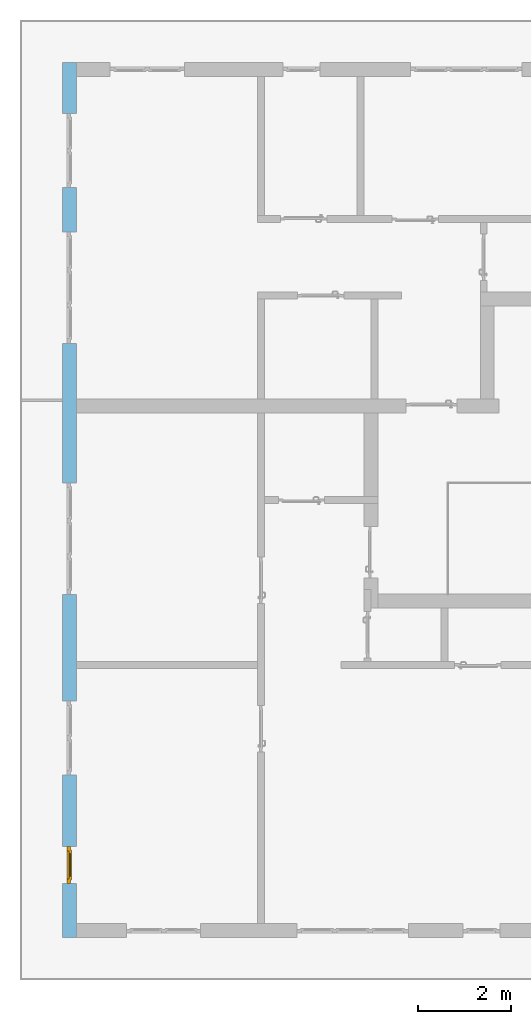
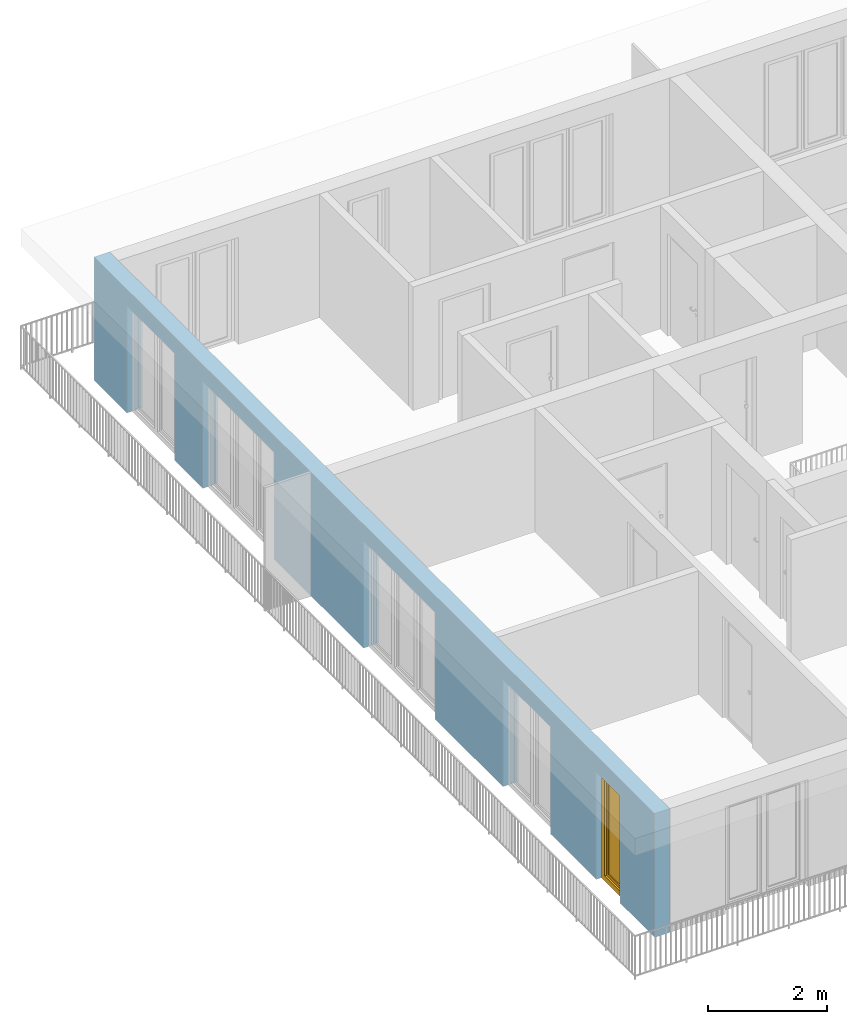
# One storey, part 12 of 54: 1 window, 5 openings, plus 1 element that does not belong to this part.
"""IFC4 building model written with IfcOpenShell, lengths in metres."""

from ifc_helpers import new_model, entity, si_unit, converted_unit, derived_unit, direction, frame, origin_with_axes, place, context, subcontext, project, spatial, polygons, source, transform, mapped, material, type_object, element, fill, save


model = new_model("IFC4")

# Units and contexts
model_context = context("Model", 3, precision=1e-05, world=origin_with_axes(), true_north=direction((0.0, 1.0)))
body_context = subcontext(model_context, "Body", "Model", "MODEL_VIEW")
ifc_project = project(units=[si_unit("LENGTHUNIT", "METRE"), si_unit("AREAUNIT", "SQUARE_METRE"), si_unit("VOLUMEUNIT", "CUBIC_METRE"), converted_unit("PLANEANGLEUNIT", "DEGREE", entity("IfcPlaneAngleMeasure", 0.0174532925199), si_unit("PLANEANGLEUNIT", "RADIAN"), dimensions=[0, 0, 0, 0, 0, 0, 0]), converted_unit("TIMEUNIT", "Year", entity("IfcTimeMeasure", 31556926.0), si_unit("TIMEUNIT", "SECOND"), dimensions=[0, 0, 1, 0, 0, 0, 0]), si_unit("MASSUNIT", "GRAM", prefix="KILO"), si_unit("THERMODYNAMICTEMPERATUREUNIT", "DEGREE_CELSIUS"), si_unit("LUMINOUSINTENSITYUNIT", "LUMEN"), si_unit("ENERGYUNIT", "JOULE", prefix="MEGA"), derived_unit("THERMALCONDUCTANCEUNIT", [(si_unit("POWERUNIT", "WATT"), 1), (si_unit("LENGTHUNIT", "METRE"), -1), (si_unit("THERMODYNAMICTEMPERATUREUNIT", "KELVIN"), -1)]), derived_unit("SPECIFICHEATCAPACITYUNIT", [(si_unit("ENERGYUNIT", "JOULE"), 1), (si_unit("MASSUNIT", "GRAM", prefix="KILO"), -1), (si_unit("THERMODYNAMICTEMPERATUREUNIT", "KELVIN"), -1)]), derived_unit("MASSDENSITYUNIT", [(si_unit("MASSUNIT", "GRAM", prefix="KILO"), 1), (si_unit("VOLUMEUNIT", "CUBIC_METRE"), -1)])], contexts=[model_context])

# Site, building, storey
site_placement = place(None, origin_with_axes())
site = spatial("IfcSite", under=ifc_project, at=site_placement, CompositionType="ELEMENT")
building_placement = place(site_placement, origin_with_axes())
building = spatial("IfcBuilding", under=site, at=building_placement, CompositionType="ELEMENT")
storey_placement = place(building_placement, frame((0.0, 0.0, 9.18), z_axis=(0.0, 0.0, 1.0), x_axis=(1.0, 0.0, 0.0)))
storey = spatial("IfcBuildingStorey", under=building, at=storey_placement, Name="3. Geschoss", CompositionType="ELEMENT", Elevation=9.18)

# Wall, openings, window
ifc_material = material()
wall_type = type_object("IfcWallType", Name="300", PredefinedType="NOTDEFINED")
wall_placement = place(storey_placement, frame((-11.7421993804, -9.92881223104, 0.0), z_axis=(0.0, 0.0, 1.0), x_axis=(0.0, 1.0, 0.0)))
wall = element("IfcWall", 1, at=wall_placement, inside=storey, type_object=wall_type, material=ifc_material, Name="Wand-001", PredefinedType="NOTDEFINED", context=body_context, shape_type="Tessellation", body=[
    polygons([(1.16441876325, -0.3, 0.0), (1.16441876325, -0.3, 2.2), (1.96441876325, -0.3, 2.2), (1.96441876325, -0.3, 0.0), (3.5, -0.3, 0.0), (3.5, -0.3, 2.2), (5.1, -0.3, 2.2), (5.1, -0.3, 0.0), (7.3921181063, -0.3, 0.0), (7.3921181063, -0.3, 2.2), (9.7921181063, -0.3, 2.2), (9.7921181063, -0.3, 0.0), (12.8, -0.3, 0.0), (12.8, -0.3, 2.2), (15.2, -0.3, 2.2), (15.2, -0.3, 0.0), (16.15, -0.3, 0.0), (16.15, -0.3, 2.2), (17.75, -0.3, 2.2), (17.75, -0.3, 0.0), (18.85, -0.3, 0.0), (18.85, -0.3, 2.54), (0.0, -0.3, 2.54), (0.0, -0.3, 0.0), (1.16441876325, -0.1, 0.0), (1.16441876325, -0.1, 2.2), (1.96441876325, -0.1, 2.2), (1.96441876325, -0.1, 0.0), (1.96441876325, 0.0, 0.0), (3.5, 0.0, 0.0), (3.5, -0.1, 0.0), (3.5, -0.1, 2.2), (5.1, -0.1, 2.2), (5.1, -0.1, 0.0), (5.1, 0.0, 0.0), (7.3921181063, 0.0, 0.0), (7.3921181063, -0.1, 0.0), (7.3921181063, -0.1, 2.2), (9.7921181063, -0.1, 2.2), (9.7921181063, -0.1, 0.0), (9.7921181063, 0.0, 0.0), (12.8, 0.0, 0.0), (12.8, -0.1, 0.0), (12.8, -0.1, 2.2), (15.2, -0.1, 2.2), (15.2, -0.1, 0.0), (15.2, 0.0, 0.0), (16.15, 0.0, 0.0), (16.15, -0.1, 0.0), (16.15, -0.1, 2.2), (17.75, -0.1, 2.2), (17.75, -0.1, 0.0), (17.75, 0.0, 0.0), (18.85, 0.0, 0.0), (18.85, 0.0, 2.54), (0.0, 0.0, 2.54), (0.0, 0.0, 0.0), (1.16441876325, 0.0, 0.0), (1.16441876325, 0.0, 2.2), (1.96441876325, 0.0, 2.2), (17.75, 0.0, 2.2), (16.15, 0.0, 2.2), (15.2, 0.0, 2.2), (12.8, 0.0, 2.2), (9.7921181063, 0.0, 2.2), (7.3921181063, 0.0, 2.2), (5.1, 0.0, 2.2), (3.5, 0.0, 2.2)], [[[1, 2, 3, 4, 5, 6, 7, 8, 9, 10, 11, 12, 13, 14, 15, 16, 17, 18, 19, 20, 21, 22, 23, 24]], [[2, 1, 25, 26]], [[3, 2, 26, 27]], [[4, 3, 27, 28]], [[4, 28, 29, 30, 31, 5]], [[31, 32, 6, 5]], [[32, 33, 7, 6]], [[33, 34, 8, 7]], [[8, 34, 35, 36, 37, 9]], [[10, 9, 37, 38]], [[11, 10, 38, 39]], [[12, 11, 39, 40]], [[12, 40, 41, 42, 43, 13]], [[43, 44, 14, 13]], [[44, 45, 15, 14]], [[45, 46, 16, 15]], [[16, 46, 47, 48, 49, 17]], [[18, 17, 49, 50]], [[19, 18, 50, 51]], [[20, 19, 51, 52]], [[52, 53, 54, 21, 20]], [[22, 21, 54, 55]], [[22, 55, 56, 23]], [[56, 57, 24, 23]], [[25, 1, 24, 57, 58]], [[26, 25, 58, 59]], [[27, 26, 59, 60]], [[28, 27, 60, 29]], [[30, 29, 60, 59, 58, 57, 56, 55, 54, 53, 61, 62, 48, 47, 63, 64, 42, 41, 65, 66, 36, 35, 67, 68]], [[30, 68, 32, 31]], [[68, 67, 33, 32]], [[67, 35, 34, 33]], [[38, 37, 36, 66]], [[39, 38, 66, 65]], [[40, 39, 65, 41]], [[42, 64, 44, 43]], [[64, 63, 45, 44]], [[63, 47, 46, 45]], [[50, 49, 48, 62]], [[51, 50, 62, 61]], [[52, 51, 61, 53]]], closed=True),
])
opening_1_placement = place(wall_placement, frame((16.95, 0.0, 0.0), z_axis=(0.0, 0.0, 1.0), x_axis=(1.0, 0.0, 0.0)))
element("IfcOpeningElement", 2, at=opening_1_placement, cuts=wall, Name="Fenster-001", context=body_context, identifier="Reference", shape_type="Tessellation", body=[
    polygons([(-0.8, -0.1, 0.0), (-0.8, -0.1, 2.2), (-0.8, 0.000999999999999, 2.2), (-0.8, 0.000999999999999, 0.0), (-0.8, -0.301, 0.0), (-0.8, -0.301, 2.2), (0.8, -0.1, 2.2), (0.8, 0.000999999999999, 2.2), (0.8, -0.301, 2.2), (0.8, 0.000999999999999, 0.0), (0.8, -0.1, 0.0), (0.8, -0.301, 0.0)], [[[1, 2, 3, 4]], [[2, 1, 5, 6]], [[7, 8, 3, 2, 6, 9]], [[8, 10, 4, 3]], [[1, 4, 10, 11, 12, 5]], [[6, 5, 12, 9]], [[7, 11, 10, 8]], [[11, 7, 9, 12]]], closed=True),
])
opening_2_placement = place(wall_placement, frame((14.0, 0.0, 0.0), z_axis=(0.0, 0.0, 1.0), x_axis=(1.0, 0.0, 0.0)))
element("IfcOpeningElement", 3, at=opening_2_placement, cuts=wall, Name="Fenster-002", context=body_context, identifier="Reference", shape_type="Tessellation", body=[
    polygons([(-1.2, -0.1, 0.0), (-1.2, -0.1, 2.2), (-1.2, 0.000999999999999, 2.2), (-1.2, 0.000999999999999, 0.0), (-1.2, -0.301, 0.0), (-1.2, -0.301, 2.2), (1.2, -0.1, 2.2), (1.2, 0.000999999999999, 2.2), (1.2, -0.301, 2.2), (1.2, 0.000999999999999, 0.0), (1.2, -0.1, 0.0), (1.2, -0.301, 0.0)], [[[1, 2, 3, 4]], [[2, 1, 5, 6]], [[7, 8, 3, 2, 6, 9]], [[8, 10, 4, 3]], [[1, 4, 10, 11, 12, 5]], [[6, 5, 12, 9]], [[7, 11, 10, 8]], [[11, 7, 9, 12]]], closed=True),
])
opening_3_placement = place(wall_placement, frame((8.5921181063, 0.0, 0.0), z_axis=(0.0, 0.0, 1.0), x_axis=(1.0, 0.0, 0.0)))
element("IfcOpeningElement", 4, at=opening_3_placement, cuts=wall, Name="Fenster-002", context=body_context, identifier="Reference", shape_type="Tessellation", body=[
    polygons([(-1.2, -0.1, 0.0), (-1.2, -0.1, 2.2), (-1.2, 0.000999999999999, 2.2), (-1.2, 0.000999999999999, 0.0), (-1.2, -0.301, 0.0), (-1.2, -0.301, 2.2), (1.2, -0.1, 2.2), (1.2, 0.000999999999999, 2.2), (1.2, -0.301, 2.2), (1.2, 0.000999999999999, 0.0), (1.2, -0.1, 0.0), (1.2, -0.301, 0.0)], [[[1, 2, 3, 4]], [[2, 1, 5, 6]], [[7, 8, 3, 2, 6, 9]], [[8, 10, 4, 3]], [[1, 4, 10, 11, 12, 5]], [[6, 5, 12, 9]], [[7, 11, 10, 8]], [[11, 7, 9, 12]]], closed=True),
])
opening_4_placement = place(wall_placement, frame((4.3, 0.0, 0.0), z_axis=(0.0, 0.0, 1.0), x_axis=(1.0, 0.0, 0.0)))
element("IfcOpeningElement", 5, at=opening_4_placement, cuts=wall, Name="Fenster-001", context=body_context, identifier="Reference", shape_type="Tessellation", body=[
    polygons([(-0.8, -0.1, 0.0), (-0.8, -0.1, 2.2), (-0.8, 0.000999999999999, 2.2), (-0.8, 0.000999999999999, 0.0), (-0.8, -0.301, 0.0), (-0.8, -0.301, 2.2), (0.8, -0.1, 2.2), (0.8, 0.000999999999999, 2.2), (0.8, -0.301, 2.2), (0.8, 0.000999999999999, 0.0), (0.8, -0.1, 0.0), (0.8, -0.301, 0.0)], [[[1, 2, 3, 4]], [[2, 1, 5, 6]], [[7, 8, 3, 2, 6, 9]], [[8, 10, 4, 3]], [[1, 4, 10, 11, 12, 5]], [[6, 5, 12, 9]], [[7, 11, 10, 8]], [[11, 7, 9, 12]]], closed=True),
])
opening_5_placement = place(wall_placement, frame((1.56441876325, 0.0, 0.0), z_axis=(0.0, 0.0, 1.0), x_axis=(1.0, 0.0, 0.0)))
opening_5 = element("IfcOpeningElement", 6, at=opening_5_placement, cuts=wall, Name="Fenster-003", context=body_context, identifier="Reference", shape_type="Tessellation", body=[
    polygons([(-0.4, -0.1, 0.0), (-0.4, -0.1, 2.2), (-0.4, 0.000999999999999, 2.2), (-0.4, 0.000999999999999, 0.0), (-0.4, -0.301, 0.0), (-0.4, -0.301, 2.2), (0.4, -0.1, 2.2), (0.4, 0.000999999999999, 2.2), (0.4, -0.301, 2.2), (0.4, 0.000999999999999, 0.0), (0.4, -0.1, 0.0), (0.4, -0.301, 0.0)], [[[1, 2, 3, 4]], [[2, 1, 5, 6]], [[7, 8, 3, 2, 6, 9]], [[8, 10, 4, 3]], [[1, 4, 10, 11, 12, 5]], [[6, 5, 12, 9]], [[7, 11, 10, 8]], [[11, 7, 9, 12]]], closed=True),
])
window_type = type_object("IfcWindowType", Name="1-26", PartitioningType="SINGLE_PANEL", PredefinedType="WINDOW")
shared_shape = source(origin_with_axes(), body_context, "Body", "Tessellation", [
    polygons([(-0.4, -0.07, 0.0), (-0.4, 0.0, 0.0), (-0.3, 0.0, 0.1), (-0.3, -0.07, 0.1), (-0.4, -0.07, 2.2), (-0.4, 0.0, 2.2), (-0.3, 0.0, 2.1), (-0.3, -0.07, 2.1)], [[[1, 2, 3, 4]], [[5, 6, 2, 1]], [[2, 6, 7, 3]], [[4, 3, 7, 8]], [[1, 4, 8, 5]], [[8, 7, 6, 5]]], closed=True),
    polygons([(0.4, -0.07, 0.0), (0.4, 0.0, 0.0), (0.4, 0.0, 2.2), (0.4, -0.07, 2.2), (0.3, -0.07, 0.1), (0.3, 0.0, 0.1), (0.3, 0.0, 2.1), (0.3, -0.07, 2.1)], [[[1, 2, 3, 4]], [[5, 6, 2, 1]], [[2, 6, 7, 3]], [[4, 3, 7, 8]], [[1, 4, 8, 5]], [[8, 7, 6, 5]]], closed=True),
    polygons([(-0.4, -0.07, 0.0), (-0.4, 0.0, 0.0), (0.4, 0.0, 0.0), (0.4, -0.07, 0.0), (-0.3, -0.07, 0.1), (-0.3, 0.0, 0.1), (0.0, 0.0, 0.1), (0.3, 0.0, 0.1), (0.3, -0.07, 0.1), (0.0, -0.07, 0.1)], [[[1, 2, 3, 4]], [[5, 6, 2, 1]], [[2, 6, 7, 8, 3]], [[4, 3, 8, 9]], [[1, 4, 9, 10, 5]], [[10, 7, 6, 5]], [[9, 8, 7, 10]]], closed=True),
    polygons([(-0.4, -0.07, 2.2), (-0.4, 0.0, 2.2), (-0.3, 0.0, 2.1), (-0.3, -0.07, 2.1), (0.4, -0.07, 2.2), (0.4, 0.0, 2.2), (0.3, 0.0, 2.1), (0.0, 0.0, 2.1), (0.0, -0.07, 2.1), (0.3, -0.07, 2.1)], [[[1, 2, 3, 4]], [[5, 6, 2, 1]], [[2, 6, 7, 8, 3]], [[4, 3, 8, 9]], [[1, 4, 9, 10, 5]], [[10, 7, 6, 5]], [[9, 8, 7, 10]]], closed=True),
    polygons([(-0.32, 0.0, 0.08), (-0.32, 0.03, 0.08), (-0.25, 0.03, 0.15), (-0.25, 0.0, 0.15), (-0.32, 0.0, 2.12), (-0.32, 0.03, 2.12), (-0.25, 0.03, 2.05), (-0.25, 0.0, 2.05)], [[[1, 2, 3, 4]], [[5, 6, 2, 1]], [[2, 6, 7, 3]], [[4, 3, 7, 8]], [[1, 4, 8, 5]], [[8, 7, 6, 5]]], closed=True),
    polygons([(0.32, 0.0, 0.08), (0.25, 0.0, 0.15), (0.25, 0.03, 0.15), (0.32, 0.03, 0.08), (0.32, 0.0, 2.12), (0.25, 0.0, 2.05), (0.25, 0.03, 2.05), (0.32, 0.03, 2.12)], [[[1, 2, 3, 4]], [[1, 5, 6, 2]], [[2, 6, 7, 3]], [[4, 3, 7, 8]], [[5, 1, 4, 8]], [[6, 5, 8, 7]]], closed=True),
    polygons([(-0.32, 0.0, 0.08), (-0.32, 0.03, 0.08), (0.32, 0.03, 0.08), (0.32, 0.0, 0.08), (-0.25, 0.0, 0.15), (-0.25, 0.03, 0.15), (0.25, 0.03, 0.15), (0.25, 0.0, 0.15)], [[[1, 2, 3, 4]], [[5, 6, 2, 1]], [[2, 6, 7, 3]], [[4, 3, 7, 8]], [[1, 4, 8, 5]], [[8, 7, 6, 5]]], closed=True),
    polygons([(-0.32, 0.0, 2.12), (0.32, 0.0, 2.12), (0.32, 0.03, 2.12), (-0.32, 0.03, 2.12), (-0.25, 0.0, 2.05), (0.25, 0.0, 2.05), (0.25, 0.03, 2.05), (-0.25, 0.03, 2.05)], [[[1, 2, 3, 4]], [[1, 5, 6, 2]], [[2, 6, 7, 3]], [[4, 3, 7, 8]], [[5, 1, 4, 8]], [[6, 5, 8, 7]]], closed=True),
    polygons([(-0.3, -0.03, 0.1), (-0.3, 0.0, 0.1), (-0.25, 0.0, 0.15), (-0.25, -0.03, 0.15), (-0.3, -0.03, 2.1), (-0.3, 0.0, 2.1), (-0.25, 0.0, 2.05), (-0.25, -0.03, 2.05)], [[[1, 2, 3, 4]], [[5, 6, 2, 1]], [[2, 6, 7, 3]], [[4, 3, 7, 8]], [[1, 4, 8, 5]], [[8, 7, 6, 5]]], closed=True),
    polygons([(0.3, -0.03, 0.1), (0.25, -0.03, 0.15), (0.25, 0.0, 0.15), (0.3, 0.0, 0.1), (0.3, -0.03, 2.1), (0.25, -0.03, 2.05), (0.25, 0.0, 2.05), (0.3, 0.0, 2.1)], [[[1, 2, 3, 4]], [[1, 5, 6, 2]], [[2, 6, 7, 3]], [[4, 3, 7, 8]], [[5, 1, 4, 8]], [[6, 5, 8, 7]]], closed=True),
    polygons([(-0.3, -0.03, 0.1), (-0.3, 0.0, 0.1), (0.3, 0.0, 0.1), (0.3, -0.03, 0.1), (-0.25, -0.03, 0.15), (-0.25, 0.0, 0.15), (0.25, 0.0, 0.15), (0.25, -0.03, 0.15)], [[[1, 2, 3, 4]], [[5, 6, 2, 1]], [[2, 6, 7, 3]], [[4, 3, 7, 8]], [[1, 4, 8, 5]], [[8, 7, 6, 5]]], closed=True),
    polygons([(-0.3, -0.03, 2.1), (0.3, -0.03, 2.1), (0.3, 0.0, 2.1), (-0.3, 0.0, 2.1), (-0.25, -0.03, 2.05), (0.25, -0.03, 2.05), (0.25, 0.0, 2.05), (-0.25, 0.0, 2.05)], [[[1, 2, 3, 4]], [[1, 5, 6, 2]], [[2, 6, 7, 3]], [[4, 3, 7, 8]], [[5, 1, 4, 8]], [[6, 5, 8, 7]]], closed=True),
    polygons([(-0.25, -0.005, 0.15), (-0.25, 0.005, 0.15), (0.25, 0.005, 0.15), (0.25, -0.005, 0.15), (-0.25, -0.005, 2.05), (-0.25, 0.005, 2.05), (0.25, 0.005, 2.05), (0.25, -0.005, 2.05)], [[[1, 2, 3, 4]], [[5, 6, 2, 1]], [[2, 6, 7, 3]], [[4, 3, 7, 8]], [[1, 4, 8, 5]], [[8, 7, 6, 5]]], closed=True),
])
window_placement = place(opening_5_placement, frame((0.4, 0.0, 0.0), z_axis=(0.0, 0.0, 1.0), x_axis=(-1.0, 0.0, 0.0)))
window = element("IfcWindow", 7, at=window_placement, inside=storey, type_object=window_type, Name="Fenster-003", OverallHeight=2.2, OverallWidth=0.8, PredefinedType="WINDOW", context=body_context, shape_type="MappedRepresentation", body=[
    mapped(shared_shape, transform((0.4, 0.17, 0.0))),
])
fill(opening_5, window)

save(model, "model.ifc")
